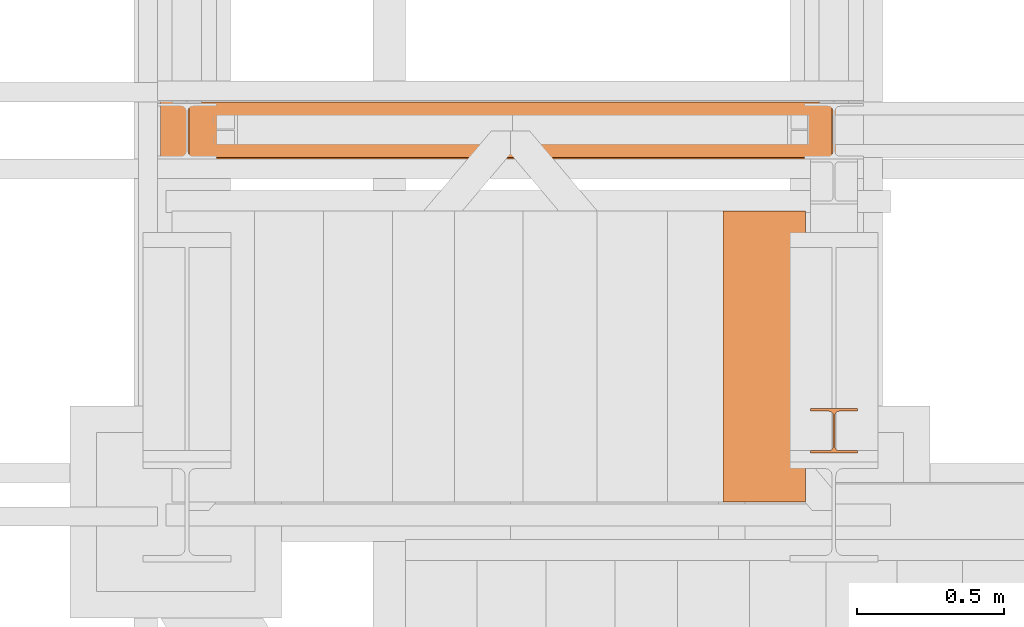
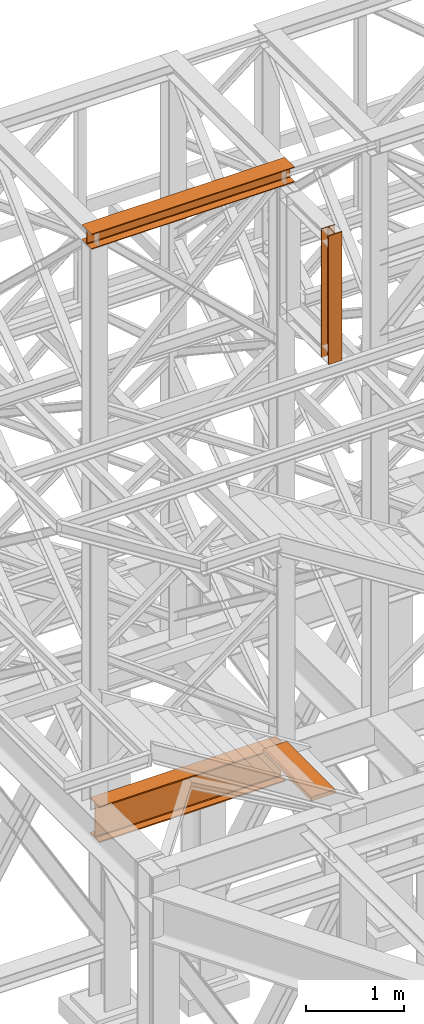
# One storey, part 87 of 208: 4 proxies.
"""IFC2X3 building model written with IfcOpenShell, lengths in millimetres."""

from ifc_helpers import new_model, entity, si_unit, converted_unit, frame, origin, origin_with_axes, place, context, subcontext, project, spatial, faceted_brep, element, save


model = new_model("IFC2X3")

# Units and contexts
model_context = context("Model", 3, precision=1e-05, world=origin())
plan_context = context("Plan", 3, precision=1e-05, world=origin())
body_context = subcontext(model_context, "Body", "Model", "MODEL_VIEW")
ifc_project = project(units=[si_unit("LENGTHUNIT", "METRE", prefix="MILLI"), converted_unit("PLANEANGLEUNIT", "DEGREE", entity("IfcPlaneAngleMeasure", 0.0174532925199433), si_unit("PLANEANGLEUNIT", "RADIAN"), dimensions=[0, 0, 0, 0, 0, 0, 0]), si_unit("AREAUNIT", "SQUARE_METRE"), si_unit("VOLUMEUNIT", "CUBIC_METRE")], contexts=[model_context, plan_context])

# Building, storey
building_placement = place(None, origin())
building = spatial("IfcBuilding", under=ifc_project, at=building_placement, CompositionType="COMPLEX")
storey_placement = place(building_placement, origin_with_axes())
storey = spatial("IfcBuildingStorey", under=building, at=storey_placement, Name="Geschoss", CompositionType="ELEMENT")

# Proxies
proxy_1_placement = place(storey_placement, frame((-3300.745031419179, -16057.57439657637, 4834.989987483023), z_axis=(0.0, 0.0, 1.0), x_axis=(1.0, 0.0, 0.0)))
element("IfcBuildingElementProxy", 1, at=proxy_1_placement, inside=storey, context=body_context, shape_type="Brep", body=[
    faceted_brep([(2188.009999895692, 0.01000000000021828, 450.0100178813937), (2188.009999895692, 190.0100125169756, 450.0100178813937), (2188.009999895692, 190.0100125169756, 435.4100240564349), (2188.009999895692, 120.7100073045494, 435.4100091552737), (2188.009999895692, 109.841562265754, 433.2347078418734), (2188.009999895692, 101.8853126263621, 425.2784563398363), (2188.009999895692, 99.71000619068764, 414.4100113010409), (2188.009999895692, 99.71000619068764, 35.60999167919181), (2188.009999895692, 101.8853126263621, 24.74154664039634), (2188.009999895692, 109.841562265754, 16.78529513835929), (2188.009999895692, 120.7100073045494, 14.60999382495902), (2188.009999895692, 190.0100125169756, 14.60999382495902), (2188.009999895692, 190.0100125169756, 0.01000000000021828), (2188.009999895692, 0.01000000000021828, 0.01000000000021828), (2188.009999895692, 0.01000000000021828, 14.60999382495902), (2188.009999895692, 69.3100052124264, 14.60999382495902), (2188.009999895692, 80.17845025122188, 16.78529513835929), (2188.009999895692, 88.13469989061377, 24.74154664039634), (2188.009999895692, 90.3100063262882, 35.60999167919181), (2188.009999895692, 90.3100063262882, 414.4100113010409), (2188.009999895692, 88.13469989061377, 425.2784563398363), (2188.009999895692, 80.17845025122188, 433.2347078418734), (2188.009999895692, 69.3100052124264, 435.4100091552737), (2188.009999895692, 0.01000000000021828, 435.4100240564349), (2188.009999895692, 190.0100125169756, 450.0100178813937), (2188.009999895692, 0.01000000000021828, 450.0100178813937), (0.01000000000021828, 0.01000000000021828, 450.0100178813937), (0.01000000000021828, 190.0100125169756, 450.0100178813937), (2188.009999895692, 190.0100125169756, 435.4100240564349), (2188.009999895692, 190.0100125169756, 450.0100178813937), (0.01000000000021828, 190.0100125169756, 450.0100178813937), (0.01000000000021828, 190.0100125169756, 435.4100240564349), (2188.009999895692, 120.7100073045494, 435.4100091552737), (2188.009999895692, 190.0100125169756, 435.4100240564349), (0.01000000000021828, 190.0100125169756, 435.4100240564349), (0.01000000000021828, 120.7100073045494, 435.4100091552737), (2188.009999895692, 109.841562265754, 433.2347078418734), (2188.009999895692, 120.7100073045494, 435.4100091552737), (0.01000000000021828, 120.7100073045494, 435.4100091552737), (0.01000000000021828, 109.841562265754, 433.2347078418734), (2188.009999895692, 101.8853126263621, 425.2784563398363), (2188.009999895692, 109.841562265754, 433.2347078418734), (0.01000000000021828, 109.841562265754, 433.2347078418734), (0.01000000000021828, 101.8853126263621, 425.2784563398363), (2188.009999895692, 99.71000619068764, 414.4100113010409), (2188.009999895692, 101.8853126263621, 425.2784563398363), (0.01000000000021828, 101.8853126263621, 425.2784563398363), (0.01000000000021828, 99.71000619068764, 414.4100113010409), (2188.009999895692, 99.71000619068764, 35.60999167919181), (2188.009999895692, 99.71000619068764, 414.4100113010409), (0.01000000000021828, 99.71000619068764, 414.4100113010409), (0.01000000000021828, 99.71000619068764, 35.60999167919181), (2188.009999895692, 101.8853126263621, 24.74154664039634), (2188.009999895692, 99.71000619068764, 35.60999167919181), (0.01000000000021828, 99.71000619068764, 35.60999167919181), (0.01000000000021828, 101.8853126263621, 24.74154664039634), (2188.009999895692, 109.841562265754, 16.78529513835929), (2188.009999895692, 101.8853126263621, 24.74154664039634), (0.01000000000021828, 101.8853126263621, 24.74154664039634), (0.01000000000021828, 109.841562265754, 16.78529513835929), (2188.009999895692, 120.7100073045494, 14.60999382495902), (2188.009999895692, 109.841562265754, 16.78529513835929), (0.01000000000021828, 109.841562265754, 16.78529513835929), (0.01000000000021828, 120.7100073045494, 14.60999382495902), (2188.009999895692, 190.0100125169756, 14.60999382495902), (2188.009999895692, 120.7100073045494, 14.60999382495902), (0.01000000000021828, 120.7100073045494, 14.60999382495902), (0.01000000000021828, 190.0100125169756, 14.60999382495902), (2188.009999895692, 190.0100125169756, 0.01000000000021828), (2188.009999895692, 190.0100125169756, 14.60999382495902), (0.01000000000021828, 190.0100125169756, 14.60999382495902), (0.01000000000021828, 190.0100125169756, 0.01000000000021828), (2188.009999895692, 0.01000000000021828, 0.01000000000021828), (2188.009999895692, 190.0100125169756, 0.01000000000021828), (0.01000000000021828, 190.0100125169756, 0.01000000000021828), (0.01000000000021828, 0.01000000000021828, 0.01000000000021828), (2188.009999895692, 0.01000000000021828, 14.60999382495902), (2188.009999895692, 0.01000000000021828, 0.01000000000021828), (0.01000000000021828, 0.01000000000021828, 0.01000000000021828), (0.01000000000021828, 0.01000000000021828, 14.60999382495902), (2188.009999895692, 69.3100052124264, 14.60999382495902), (2188.009999895692, 0.01000000000021828, 14.60999382495902), (0.01000000000021828, 0.01000000000021828, 14.60999382495902), (0.01000000000021828, 69.3100052124264, 14.60999382495902), (2188.009999895692, 80.17845025122188, 16.78529513835929), (2188.009999895692, 69.3100052124264, 14.60999382495902), (0.01000000000021828, 69.3100052124264, 14.60999382495902), (0.01000000000021828, 80.17845025122188, 16.78529513835929), (2188.009999895692, 88.13469989061377, 24.74154664039634), (2188.009999895692, 80.17845025122188, 16.78529513835929), (0.01000000000021828, 80.17845025122188, 16.78529513835929), (0.01000000000021828, 88.13469989061377, 24.74154664039634), (2188.009999895692, 90.3100063262882, 35.60999167919181), (2188.009999895692, 88.13469989061377, 24.74154664039634), (0.01000000000021828, 88.13469989061377, 24.74154664039634), (0.01000000000021828, 90.3100063262882, 35.60999167919181), (2188.009999895692, 90.3100063262882, 414.4100113010409), (2188.009999895692, 90.3100063262882, 35.60999167919181), (0.01000000000021828, 90.3100063262882, 35.60999167919181), (0.01000000000021828, 90.3100063262882, 414.4100113010409), (2188.009999895692, 88.13469989061377, 425.2784563398363), (2188.009999895692, 90.3100063262882, 414.4100113010409), (0.01000000000021828, 90.3100063262882, 414.4100113010409), (0.01000000000021828, 88.13469989061377, 425.2784563398363), (2188.009999895692, 80.17845025122188, 433.2347078418734), (2188.009999895692, 88.13469989061377, 425.2784563398363), (0.01000000000021828, 88.13469989061377, 425.2784563398363), (0.01000000000021828, 80.17845025122188, 433.2347078418734), (2188.009999895692, 69.3100052124264, 435.4100091552737), (2188.009999895692, 80.17845025122188, 433.2347078418734), (0.01000000000021828, 80.17845025122188, 433.2347078418734), (0.01000000000021828, 69.3100052124264, 435.4100091552737), (2188.009999895692, 0.01000000000021828, 435.4100240564349), (2188.009999895692, 69.3100052124264, 435.4100091552737), (0.01000000000021828, 69.3100052124264, 435.4100091552737), (0.01000000000021828, 0.01000000000021828, 435.4100240564349), (2188.009999895692, 0.01000000000021828, 450.0100178813937), (2188.009999895692, 0.01000000000021828, 435.4100240564349), (0.01000000000021828, 0.01000000000021828, 435.4100240564349), (0.01000000000021828, 0.01000000000021828, 450.0100178813937), (0.01000000000021828, 0.01000000000021828, 450.0100178813937), (0.01000000000021828, 0.01000000000021828, 435.4100240564349), (0.01000000000021828, 69.3100052124264, 435.4100091552737), (0.01000000000021828, 80.17845025122188, 433.2347078418734), (0.01000000000021828, 88.13469989061377, 425.2784563398363), (0.01000000000021828, 90.3100063262882, 414.4100113010409), (0.01000000000021828, 90.3100063262882, 35.60999167919181), (0.01000000000021828, 88.13469989061377, 24.74154664039634), (0.01000000000021828, 80.17845025122188, 16.78529513835929), (0.01000000000021828, 69.3100052124264, 14.60999382495902), (0.01000000000021828, 0.01000000000021828, 14.60999382495902), (0.01000000000021828, 0.01000000000021828, 0.01000000000021828), (0.01000000000021828, 190.0100125169756, 0.01000000000021828), (0.01000000000021828, 190.0100125169756, 14.60999382495902), (0.01000000000021828, 120.7100073045494, 14.60999382495902), (0.01000000000021828, 109.841562265754, 16.78529513835929), (0.01000000000021828, 101.8853126263621, 24.74154664039634), (0.01000000000021828, 99.71000619068764, 35.60999167919181), (0.01000000000021828, 99.71000619068764, 414.4100113010409), (0.01000000000021828, 101.8853126263621, 425.2784563398363), (0.01000000000021828, 109.841562265754, 433.2347078418734), (0.01000000000021828, 120.7100073045494, 435.4100091552737), (0.01000000000021828, 190.0100125169756, 435.4100240564349), (0.01000000000021828, 190.0100125169756, 450.0100178813937)], [[[0, 1, 2, 3, 4, 5, 6, 7, 8, 9, 10, 11, 12, 13, 14, 15, 16, 17, 18, 19, 20, 21, 22, 23]], [[24, 25, 26, 27]], [[28, 29, 30, 31]], [[32, 33, 34, 35]], [[36, 37, 38, 39]], [[40, 41, 42, 43]], [[44, 45, 46, 47]], [[48, 49, 50, 51]], [[52, 53, 54, 55]], [[56, 57, 58, 59]], [[60, 61, 62, 63]], [[64, 65, 66, 67]], [[68, 69, 70, 71]], [[72, 73, 74, 75]], [[76, 77, 78, 79]], [[80, 81, 82, 83]], [[84, 85, 86, 87]], [[88, 89, 90, 91]], [[92, 93, 94, 95]], [[96, 97, 98, 99]], [[100, 101, 102, 103]], [[104, 105, 106, 107]], [[108, 109, 110, 111]], [[112, 113, 114, 115]], [[116, 117, 118, 119]], [[120, 121, 122, 123, 124, 125, 126, 127, 128, 129, 130, 131, 132, 133, 134, 135, 136, 137, 138, 139, 140, 141, 142, 143]]], orient=[[False], [False], [False], [False], [False], [False], [False], [False], [False], [False], [False], [False], [False], [False], [False], [False], [False], [False], [False], [False], [False], [False], [False], [False], [False], [False]]),
])
proxy_2_placement = place(storey_placement, frame((-3396.582763865856, -16062.57439180801, 12249.99005869381), z_axis=(0.0, 0.0, 1.0), x_axis=(1.0, 0.0, 0.0)))
element("IfcBuildingElementProxy", 2, at=proxy_2_placement, inside=storey, context=body_context, shape_type="Brep", body=[
    faceted_brep([(0.009999999999763531, 0.01000000000021828, 0.01000000000021828), (0.009999999999763531, 200.0100029802325, 0.01000000000021828), (0.009999999999763531, 200.0100029802325, 10.00999791383765), (0.009999999999763531, 121.2600035762789, 10.01000536441825), (0.009999999999763531, 111.9441915473344, 11.87455041170142), (0.009999999999763531, 105.1245498640838, 18.69419349193595), (0.009999999999763531, 103.2600015571716, 28.01000458955787), (0.009999999999763531, 103.2600015571716, 162.0100153779986), (0.009999999999763531, 105.1245498640838, 171.3258264756205), (0.009999999999763531, 111.9441915473344, 178.145469555855), (0.009999999999763531, 121.2600035762789, 180.0100146031382), (0.009999999999763531, 200.0100029802325, 180.0100146031382), (0.009999999999763531, 200.0100029802325, 190.0100125169756), (0.009999999999763531, 0.01000000000021828, 190.0100125169756), (0.009999999999763531, 0.01000000000021828, 180.0100146031382), (0.009999999999763531, 78.75999940395377, 180.0100146031382), (0.009999999999763531, 88.07581143289826, 178.145469555855), (0.009999999999763531, 94.89545311614893, 171.3258264756205), (0.009999999999763531, 96.76000142306111, 162.0100153779986), (0.009999999999763531, 96.76000142306111, 28.01000458955787), (0.009999999999763531, 94.89545311614893, 18.69419349193595), (0.009999999999763531, 88.07581143289826, 11.87455041170142), (0.009999999999763531, 78.75999940395377, 10.01000536441825), (0.009999999999763531, 0.01000000000021828, 10.00999791383765), (0.009999999999763531, 200.0100029802325, 0.01000000000021828), (0.009999999999763531, 0.01000000000021828, 0.01000000000021828), (2390.010012516976, 0.01000000000021828, 0.01000000000021828), (2390.010012516976, 200.0100029802325, 0.01000000000021828), (0.009999999999763531, 200.0100029802325, 10.00999791383765), (0.009999999999763531, 200.0100029802325, 0.01000000000021828), (2390.010012516976, 200.0100029802325, 0.01000000000021828), (2390.010012516976, 200.0100029802325, 10.00999791383765), (0.009999999999763531, 121.2600035762789, 10.01000536441825), (0.009999999999763531, 200.0100029802325, 10.00999791383765), (2390.010012516976, 200.0100029802325, 10.00999791383765), (2390.010012516976, 121.2600035762789, 10.01000536441825), (0.009999999999763531, 111.9441915473344, 11.87455041170142), (0.009999999999763531, 121.2600035762789, 10.01000536441825), (2390.010012516976, 121.2600035762789, 10.01000536441825), (2390.010012516976, 111.9441915473344, 11.87455041170142), (0.009999999999763531, 105.1245498640838, 18.69419349193595), (0.009999999999763531, 111.9441915473344, 11.87455041170142), (2390.010012516976, 111.9441915473344, 11.87455041170142), (2390.010012516976, 105.1245498640838, 18.69419349193595), (0.009999999999763531, 103.2600015571716, 28.01000458955787), (0.009999999999763531, 105.1245498640838, 18.69419349193595), (2390.010012516976, 105.1245498640838, 18.69419349193595), (2390.010012516976, 103.2600015571716, 28.01000458955787), (0.009999999999763531, 103.2600015571716, 162.0100153779986), (0.009999999999763531, 103.2600015571716, 28.01000458955787), (2390.010012516976, 103.2600015571716, 28.01000458955787), (2390.010012516976, 103.2600015571716, 162.0100153779986), (0.009999999999763531, 105.1245498640838, 171.3258264756205), (0.009999999999763531, 103.2600015571716, 162.0100153779986), (2390.010012516976, 103.2600015571716, 162.0100153779986), (2390.010012516976, 105.1245498640838, 171.3258264756205), (0.009999999999763531, 111.9441915473344, 178.145469555855), (0.009999999999763531, 105.1245498640838, 171.3258264756205), (2390.010012516976, 105.1245498640838, 171.3258264756205), (2390.010012516976, 111.9441915473344, 178.145469555855), (0.009999999999763531, 121.2600035762789, 180.0100146031382), (0.009999999999763531, 111.9441915473344, 178.145469555855), (2390.010012516976, 111.9441915473344, 178.145469555855), (2390.010012516976, 121.2600035762789, 180.0100146031382), (0.009999999999763531, 200.0100029802325, 180.0100146031382), (0.009999999999763531, 121.2600035762789, 180.0100146031382), (2390.010012516976, 121.2600035762789, 180.0100146031382), (2390.010012516976, 200.0100029802325, 180.0100146031382), (0.009999999999763531, 200.0100029802325, 190.0100125169756), (0.009999999999763531, 200.0100029802325, 180.0100146031382), (2390.010012516976, 200.0100029802325, 180.0100146031382), (2390.010012516976, 200.0100029802325, 190.0100125169756), (0.009999999999763531, 0.01000000000021828, 190.0100125169756), (0.009999999999763531, 200.0100029802325, 190.0100125169756), (2390.010012516976, 200.0100029802325, 190.0100125169756), (2390.010012516976, 0.01000000000021828, 190.0100125169756), (0.009999999999763531, 0.01000000000021828, 180.0100146031382), (0.009999999999763531, 0.01000000000021828, 190.0100125169756), (2390.010012516976, 0.01000000000021828, 190.0100125169756), (2390.010012516976, 0.01000000000021828, 180.0100146031382), (0.009999999999763531, 78.75999940395377, 180.0100146031382), (0.009999999999763531, 0.01000000000021828, 180.0100146031382), (2390.010012516976, 0.01000000000021828, 180.0100146031382), (2390.010012516976, 78.75999940395377, 180.0100146031382), (0.009999999999763531, 88.07581143289826, 178.145469555855), (0.009999999999763531, 78.75999940395377, 180.0100146031382), (2390.010012516976, 78.75999940395377, 180.0100146031382), (2390.010012516976, 88.07581143289826, 178.145469555855), (0.009999999999763531, 94.89545311614893, 171.3258264756205), (0.009999999999763531, 88.07581143289826, 178.145469555855), (2390.010012516976, 88.07581143289826, 178.145469555855), (2390.010012516976, 94.89545311614893, 171.3258264756205), (0.009999999999763531, 96.76000142306111, 162.0100153779986), (0.009999999999763531, 94.89545311614893, 171.3258264756205), (2390.010012516976, 94.89545311614893, 171.3258264756205), (2390.010012516976, 96.76000142306111, 162.0100153779986), (0.009999999999763531, 96.76000142306111, 28.01000458955787), (0.009999999999763531, 96.76000142306111, 162.0100153779986), (2390.010012516976, 96.76000142306111, 162.0100153779986), (2390.010012516976, 96.76000142306111, 28.01000458955787), (0.009999999999763531, 94.89545311614893, 18.69419349193595), (0.009999999999763531, 96.76000142306111, 28.01000458955787), (2390.010012516976, 96.76000142306111, 28.01000458955787), (2390.010012516976, 94.89545311614893, 18.69419349193595), (0.009999999999763531, 88.07581143289826, 11.87455041170142), (0.009999999999763531, 94.89545311614893, 18.69419349193595), (2390.010012516976, 94.89545311614893, 18.69419349193595), (2390.010012516976, 88.07581143289826, 11.87455041170142), (0.009999999999763531, 78.75999940395377, 10.01000536441825), (0.009999999999763531, 88.07581143289826, 11.87455041170142), (2390.010012516976, 88.07581143289826, 11.87455041170142), (2390.010012516976, 78.75999940395377, 10.01000536441825), (0.009999999999763531, 0.01000000000021828, 10.00999791383765), (0.009999999999763531, 78.75999940395377, 10.01000536441825), (2390.010012516976, 78.75999940395377, 10.01000536441825), (2390.010012516976, 0.01000000000021828, 10.00999791383765), (0.009999999999763531, 0.01000000000021828, 0.01000000000021828), (0.009999999999763531, 0.01000000000021828, 10.00999791383765), (2390.010012516976, 0.01000000000021828, 10.00999791383765), (2390.010012516976, 0.01000000000021828, 0.01000000000021828), (2390.010012516976, 0.01000000000021828, 0.01000000000021828), (2390.010012516976, 0.01000000000021828, 10.00999791383765), (2390.010012516976, 78.75999940395377, 10.01000536441825), (2390.010012516976, 88.07581143289826, 11.87455041170142), (2390.010012516976, 94.89545311614893, 18.69419349193595), (2390.010012516976, 96.76000142306111, 28.01000458955787), (2390.010012516976, 96.76000142306111, 162.0100153779986), (2390.010012516976, 94.89545311614893, 171.3258264756205), (2390.010012516976, 88.07581143289826, 178.145469555855), (2390.010012516976, 78.75999940395377, 180.0100146031382), (2390.010012516976, 0.01000000000021828, 180.0100146031382), (2390.010012516976, 0.01000000000021828, 190.0100125169756), (2390.010012516976, 200.0100029802325, 190.0100125169756), (2390.010012516976, 200.0100029802325, 180.0100146031382), (2390.010012516976, 121.2600035762789, 180.0100146031382), (2390.010012516976, 111.9441915473344, 178.145469555855), (2390.010012516976, 105.1245498640838, 171.3258264756205), (2390.010012516976, 103.2600015571716, 162.0100153779986), (2390.010012516976, 103.2600015571716, 28.01000458955787), (2390.010012516976, 105.1245498640838, 18.69419349193595), (2390.010012516976, 111.9441915473344, 11.87455041170142), (2390.010012516976, 121.2600035762789, 10.01000536441825), (2390.010012516976, 200.0100029802325, 10.00999791383765), (2390.010012516976, 200.0100029802325, 0.01000000000021828)], [[[0, 1, 2, 3, 4, 5, 6, 7, 8, 9, 10, 11, 12, 13, 14, 15, 16, 17, 18, 19, 20, 21, 22, 23]], [[24, 25, 26, 27]], [[28, 29, 30, 31]], [[32, 33, 34, 35]], [[36, 37, 38, 39]], [[40, 41, 42, 43]], [[44, 45, 46, 47]], [[48, 49, 50, 51]], [[52, 53, 54, 55]], [[56, 57, 58, 59]], [[60, 61, 62, 63]], [[64, 65, 66, 67]], [[68, 69, 70, 71]], [[72, 73, 74, 75]], [[76, 77, 78, 79]], [[80, 81, 82, 83]], [[84, 85, 86, 87]], [[88, 89, 90, 91]], [[92, 93, 94, 95]], [[96, 97, 98, 99]], [[100, 101, 102, 103]], [[104, 105, 106, 107]], [[108, 109, 110, 111]], [[112, 113, 114, 115]], [[116, 117, 118, 119]], [[120, 121, 122, 123, 124, 125, 126, 127, 128, 129, 130, 131, 132, 133, 134, 135, 136, 137, 138, 139, 140, 141, 142, 143]]], orient=[[False], [False], [False], [False], [False], [False], [False], [False], [False], [False], [False], [False], [False], [False], [False], [False], [False], [False], [False], [False], [False], [False], [False], [False], [False], [False]]),
])
proxy_3_placement = place(storey_placement, frame((-1186.582758501437, -17062.574391808, 10649.99005869381), z_axis=(0.0, 0.0, 1.0), x_axis=(1.0, 0.0, 0.0)))
element("IfcBuildingElementProxy", 3, at=proxy_3_placement, inside=storey, context=body_context, shape_type="Brep", body=[
    faceted_brep([(160.0100113248825, 0.00999999999839929, 0.01000000000021828), (160.0100113248825, 9.010003337858507, 0.01000000000021828), (98.01000675022601, 9.010003337858507, 0.01000000000021828), (90.24683052510022, 10.56379211902458, 0.01000000000021828), (84.56379586666822, 16.24682677745659, 0.01000000000021828), (83.01000568851828, 24.01000020861466, 0.01000000000021828), (83.01000568851828, 128.0100060796722, 0.01000000000021828), (84.56379586666822, 135.7731832361205, 0.01000000000021828), (90.24683052510022, 141.4562178945525, 0.01000000000021828), (98.01000675022601, 143.0100066757186, 0.01000000000021828), (160.0100113248825, 143.0100066757186, 0.01000000000021828), (160.0100113248825, 152.0100100135787, 0.01000000000021828), (0.009999999999990905, 152.0100100135787, 0.01000000000021828), (0.009999999999990905, 143.0100066757186, 0.01000000000021828), (62.01000457465648, 143.0100066757186, 0.01000000000021828), (69.77318079978227, 141.4562178945525, 0.01000000000021828), (75.45621545821427, 135.7731832361205, 0.01000000000021828), (77.01000563636421, 128.0100060796722, 0.01000000000021828), (77.01000563636421, 24.01000020861466, 0.01000000000021828), (75.45621545821427, 16.24682677745659, 0.01000000000021828), (69.77318079978227, 10.56379211902458, 0.01000000000021828), (62.01000457465648, 9.010003337858507, 0.01000000000021828), (0.009999999999990905, 9.010003337858507, 0.01000000000021828), (0.009999999999990905, 0.00999999999839929, 0.01000000000021828), (0.009999999999990905, 0.00999999999839929, 0.01000000000021828), (0.009999999999990905, 0.00999999999839929, 1600.01), (160.0100113248789, 0.00999999999839929, 1600.01), (160.0100113248825, 0.00999999999839929, 0.01000000000021828), (0.009999999999990905, 9.010003337858507, 0.01000000000021828), (0.009999999999990905, 9.010003337858507, 1600.01), (0.009999999999990905, 0.00999999999839929, 1600.01), (0.009999999999990905, 0.00999999999839929, 0.01000000000021828), (62.01000457465648, 9.010003337858507, 0.01000000000021828), (62.01000457465648, 9.010003337858507, 1600.01), (0.009999999999990905, 9.010003337858507, 1600.01), (0.009999999999990905, 9.010003337858507, 0.01000000000021828), (69.77318079978227, 10.56379211902458, 0.01000000000021828), (69.77318079977863, 10.56379211902458, 1600.01), (62.01000457465648, 9.010003337858507, 1600.01), (62.01000457465648, 9.010003337858507, 0.01000000000021828), (75.45621545821427, 16.24682677745659, 0.01000000000021828), (75.45621545821064, 16.24682677745659, 1600.01), (69.77318079977863, 10.56379211902458, 1600.01), (69.77318079978227, 10.56379211902458, 0.01000000000021828), (77.01000563636421, 24.01000020861466, 0.01000000000021828), (77.01000563636057, 24.01000020861466, 1600.01), (75.45621545821064, 16.24682677745659, 1600.01), (75.45621545821427, 16.24682677745659, 0.01000000000021828), (77.01000563636421, 128.0100060796722, 0.01000000000021828), (77.01000563636057, 128.0100060796722, 1600.01), (77.01000563636057, 24.01000020861466, 1600.01), (77.01000563636421, 24.01000020861466, 0.01000000000021828), (75.45621545821427, 135.7731832361205, 0.01000000000021828), (75.45621545821064, 135.7731832361205, 1600.01), (77.01000563636057, 128.0100060796722, 1600.01), (77.01000563636421, 128.0100060796722, 0.01000000000021828), (69.77318079978227, 141.4562178945525, 0.01000000000021828), (69.77318079977863, 141.4562178945525, 1600.01), (75.45621545821064, 135.7731832361205, 1600.01), (75.45621545821427, 135.7731832361205, 0.01000000000021828), (62.01000457465648, 143.0100066757186, 0.01000000000021828), (62.01000457465284, 143.0100066757186, 1600.01), (69.77318079977863, 141.4562178945525, 1600.01), (69.77318079978227, 141.4562178945525, 0.01000000000021828), (0.009999999999990905, 143.0100066757186, 0.01000000000021828), (0.009999999999990905, 143.0100066757186, 1600.01), (62.01000457465284, 143.0100066757186, 1600.01), (62.01000457465648, 143.0100066757186, 0.01000000000021828), (0.009999999999990905, 152.0100100135787, 0.01000000000021828), (0.009999999999990905, 152.0100100135787, 1600.01), (0.009999999999990905, 143.0100066757186, 1600.01), (0.009999999999990905, 143.0100066757186, 0.01000000000021828), (160.0100113248825, 152.0100100135787, 0.01000000000021828), (160.0100113248825, 152.0100100135787, 1600.01), (0.009999999999990905, 152.0100100135787, 1600.01), (0.009999999999990905, 152.0100100135787, 0.01000000000021828), (160.0100113248825, 143.0100066757186, 0.01000000000021828), (160.0100113248825, 143.0100066757186, 1600.01), (160.0100113248825, 152.0100100135787, 1600.01), (160.0100113248825, 152.0100100135787, 0.01000000000021828), (98.01000675022601, 143.0100066757186, 0.01000000000021828), (98.01000675022237, 143.0100066757186, 1600.01), (160.0100113248825, 143.0100066757186, 1600.01), (160.0100113248825, 143.0100066757186, 0.01000000000021828), (90.24683052510022, 141.4562178945525, 0.01000000000021828), (90.24683052509658, 141.4562178945525, 1600.01), (98.01000675022237, 143.0100066757186, 1600.01), (98.01000675022601, 143.0100066757186, 0.01000000000021828), (84.56379586666822, 135.7731832361205, 0.01000000000021828), (84.56379586666458, 135.7731832361205, 1600.01), (90.24683052509658, 141.4562178945525, 1600.01), (90.24683052510022, 141.4562178945525, 0.01000000000021828), (83.01000568851828, 128.0100060796722, 0.01000000000021828), (83.01000568851464, 128.0100060796722, 1600.01), (84.56379586666458, 135.7731832361205, 1600.01), (84.56379586666822, 135.7731832361205, 0.01000000000021828), (83.01000568851828, 24.01000020861466, 0.01000000000021828), (83.01000568851464, 24.01000020861466, 1600.01), (83.01000568851464, 128.0100060796722, 1600.01), (83.01000568851828, 128.0100060796722, 0.01000000000021828), (84.56379586666822, 16.24682677745659, 0.01000000000021828), (84.56379586666458, 16.24682677745659, 1600.01), (83.01000568851464, 24.01000020861466, 1600.01), (83.01000568851828, 24.01000020861466, 0.01000000000021828), (90.24683052510022, 10.56379211902458, 0.01000000000021828), (90.24683052509658, 10.56379211902458, 1600.01), (84.56379586666458, 16.24682677745659, 1600.01), (84.56379586666822, 16.24682677745659, 0.01000000000021828), (98.01000675022601, 9.010003337858507, 0.01000000000021828), (98.01000675022237, 9.010003337858507, 1600.01), (90.24683052509658, 10.56379211902458, 1600.01), (90.24683052510022, 10.56379211902458, 0.01000000000021828), (160.0100113248825, 9.010003337858507, 0.01000000000021828), (160.0100113248825, 9.010003337858507, 1600.01), (98.01000675022237, 9.010003337858507, 1600.01), (98.01000675022601, 9.010003337858507, 0.01000000000021828), (160.0100113248825, 0.00999999999839929, 0.01000000000021828), (160.0100113248789, 0.00999999999839929, 1600.01), (160.0100113248825, 9.010003337858507, 1600.01), (160.0100113248825, 9.010003337858507, 0.01000000000021828), (160.0100113248789, 0.00999999999839929, 1600.01), (0.009999999999990905, 0.00999999999839929, 1600.01), (0.009999999999990905, 9.010003337858507, 1600.01), (62.01000457465648, 9.010003337858507, 1600.01), (69.77318079977863, 10.56379211902458, 1600.01), (75.45621545821064, 16.24682677745659, 1600.01), (77.01000563636057, 24.01000020861466, 1600.01), (77.01000563636057, 128.0100060796722, 1600.01), (75.45621545821064, 135.7731832361205, 1600.01), (69.77318079977863, 141.4562178945525, 1600.01), (62.01000457465284, 143.0100066757186, 1600.01), (0.009999999999990905, 143.0100066757186, 1600.01), (0.009999999999990905, 152.0100100135787, 1600.01), (160.0100113248825, 152.0100100135787, 1600.01), (160.0100113248825, 143.0100066757186, 1600.01), (98.01000675022237, 143.0100066757186, 1600.01), (90.24683052509658, 141.4562178945525, 1600.01), (84.56379586666458, 135.7731832361205, 1600.01), (83.01000568851464, 128.0100060796722, 1600.01), (83.01000568851464, 24.01000020861466, 1600.01), (84.56379586666458, 16.24682677745659, 1600.01), (90.24683052509658, 10.56379211902458, 1600.01), (98.01000675022237, 9.010003337858507, 1600.01), (160.0100113248825, 9.010003337858507, 1600.01)], [[[0, 1, 2, 3, 4, 5, 6, 7, 8, 9, 10, 11, 12, 13, 14, 15, 16, 17, 18, 19, 20, 21, 22, 23]], [[24, 25, 26, 27]], [[28, 29, 30, 31]], [[32, 33, 34, 35]], [[36, 37, 38, 39]], [[40, 41, 42, 43]], [[44, 45, 46, 47]], [[48, 49, 50, 51]], [[52, 53, 54, 55]], [[56, 57, 58, 59]], [[60, 61, 62, 63]], [[64, 65, 66, 67]], [[68, 69, 70, 71]], [[72, 73, 74, 75]], [[76, 77, 78, 79]], [[80, 81, 82, 83]], [[84, 85, 86, 87]], [[88, 89, 90, 91]], [[92, 93, 94, 95]], [[96, 97, 98, 99]], [[100, 101, 102, 103]], [[104, 105, 106, 107]], [[108, 109, 110, 111]], [[112, 113, 114, 115]], [[116, 117, 118, 119]], [[120, 121, 122, 123, 124, 125, 126, 127, 128, 129, 130, 131, 132, 133, 134, 135, 136, 137, 138, 139, 140, 141, 142, 143]]], orient=[[False], [False], [False], [False], [False], [False], [False], [False], [False], [False], [False], [False], [False], [False], [False], [False], [False], [False], [False], [False], [False], [False], [False], [False], [False], [False]]),
])
proxy_4_placement = place(storey_placement, frame((-1483.793599482343, -17228.55346893691, 5425.907862574692), z_axis=(0.0, 0.0, 1.0), x_axis=(1.0, 0.0, 0.0)))
element("IfcBuildingElementProxy", 4, at=proxy_4_placement, inside=storey, context=body_context, shape_type="Brep", body=[
    faceted_brep([(0.009999999999990905, 0.00999999999839929, 0.01000000000021828), (280.2746556316176, 0.00999999999839929, 0.01000000000021828), (280.2746556316176, 988.9080206708568, 0.01000000000021828), (0.009999999999990905, 988.9080206708568, 0.01000000000021828), (280.2746556316176, 0.00999999999839929, 50.01000000000022), (0.009999999999990905, 0.00999999999839929, 50.01000000000022), (0.009999999999990905, 988.9080206708568, 50.01000000000022), (280.2746556316176, 988.9080206708568, 50.01000000000022), (280.2746556316176, 0.00999999999839929, 0.01000000000021828), (0.009999999999990905, 0.00999999999839929, 0.01000000000021828), (0.009999999999990905, 0.00999999999839929, 50.01000000000022), (280.2746556316176, 0.00999999999839929, 50.01000000000022), (280.2746556316176, 988.9080206708568, 0.01000000000021828), (280.2746556316176, 0.00999999999839929, 0.01000000000021828), (280.2746556316176, 0.00999999999839929, 50.01000000000022), (280.2746556316176, 988.9080206708568, 50.01000000000022), (0.009999999999990905, 988.9080206708568, 0.01000000000021828), (280.2746556316176, 988.9080206708568, 0.01000000000021828), (280.2746556316176, 988.9080206708568, 50.01000000000022), (0.009999999999990905, 988.9080206708568, 50.01000000000022), (0.009999999999990905, 0.00999999999839929, 0.01000000000021828), (0.009999999999990905, 988.9080206708568, 0.01000000000021828), (0.009999999999990905, 988.9080206708568, 50.01000000000022), (0.009999999999990905, 0.00999999999839929, 50.01000000000022)], [[[0, 1, 2, 3]], [[4, 5, 6, 7]], [[8, 9, 10, 11]], [[12, 13, 14, 15]], [[16, 17, 18, 19]], [[20, 21, 22, 23]]], orient=[[False], [False], [False], [False], [False], [False]]),
])

save(model, "model.ifc")
